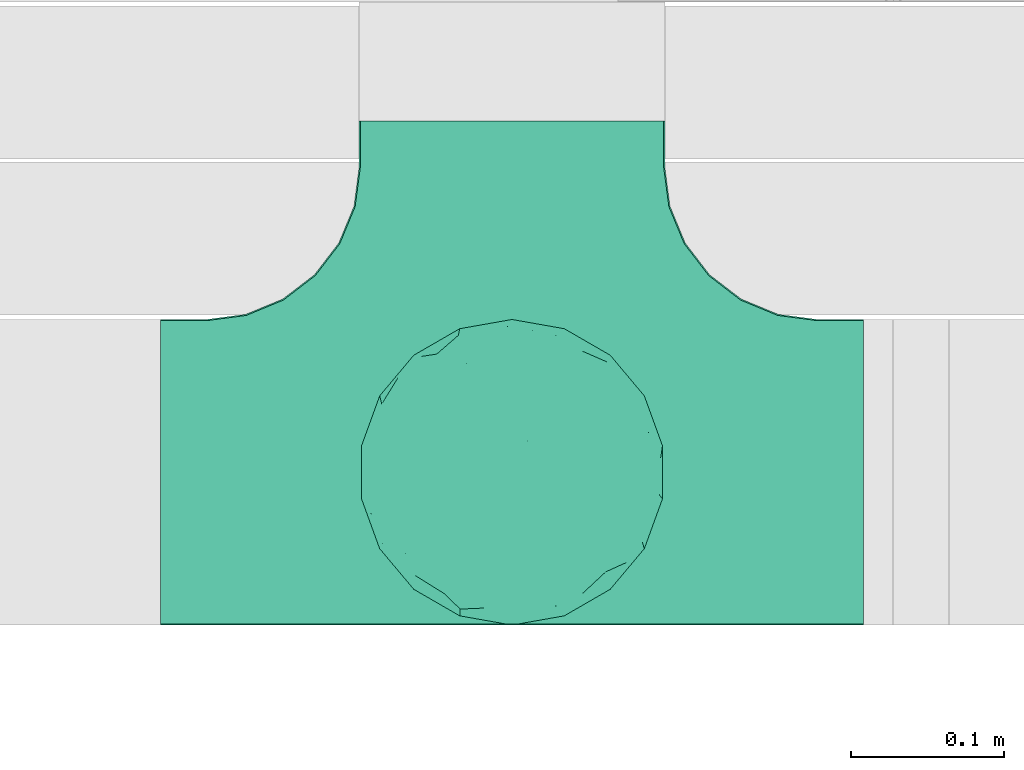
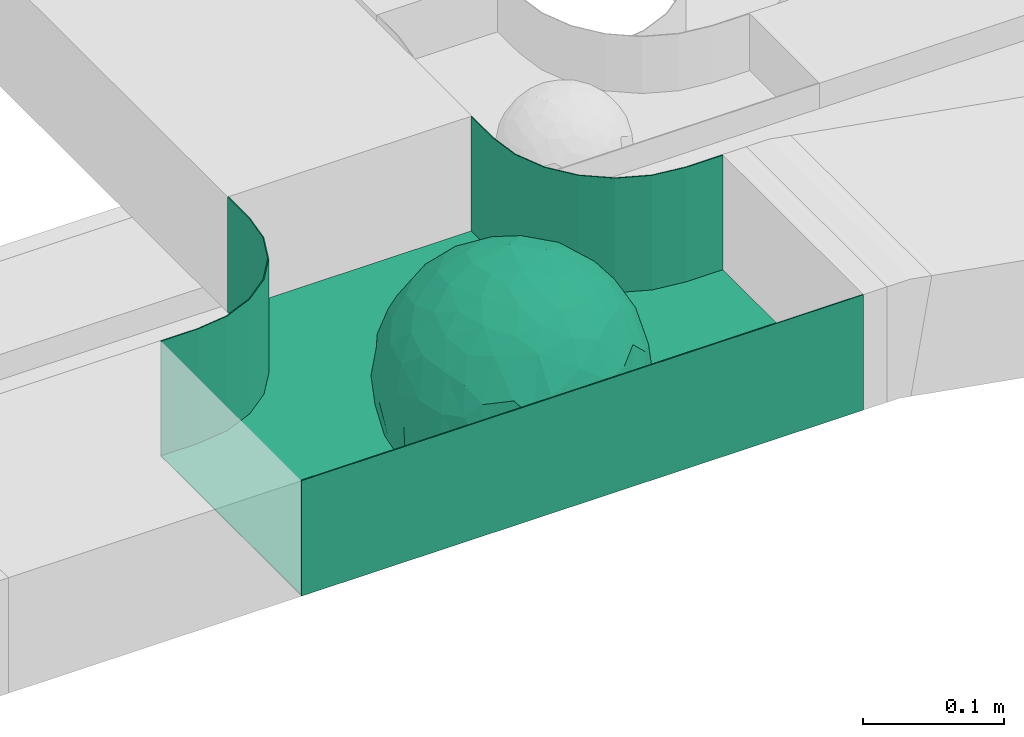
# One storey, part 36 of 38: 1 flow fitting.
"""IFC2X3 building model written with IfcOpenShell, lengths in millimetres."""

from ifc_helpers import new_model, entity, si_unit, converted_unit, derived_unit, direction, frame, origin, place, context, subcontext, project, spatial, faceted_brep, source, transform, mapped, material, material_list, type_object, type_shapes, element, save


model = new_model("IFC2X3")

# Units and contexts
model_context = context("Model", 3, precision=0.01, world=origin(), true_north=direction((6.12303176911189e-17, 1.0)))
body_context = subcontext(model_context, "Body", "Model", "MODEL_VIEW")
ifc_project = project(units=[si_unit("LENGTHUNIT", "METRE", prefix="MILLI"), si_unit("AREAUNIT", "SQUARE_METRE"), si_unit("VOLUMEUNIT", "CUBIC_METRE"), converted_unit("PLANEANGLEUNIT", "DEGREE", entity("IfcRatioMeasure", 0.0174532925199433), si_unit("PLANEANGLEUNIT", "RADIAN"), dimensions=[0, 0, 0, 0, 0, 0, 0]), si_unit("MASSUNIT", "GRAM", prefix="KILO"), derived_unit("MASSDENSITYUNIT", [(si_unit("MASSUNIT", "GRAM", prefix="KILO"), 1), (si_unit("LENGTHUNIT", "METRE"), -3)]), derived_unit("MOMENTOFINERTIAUNIT", [(si_unit("LENGTHUNIT", "METRE"), 4)]), si_unit("TIMEUNIT", "SECOND"), si_unit("FREQUENCYUNIT", "HERTZ"), si_unit("THERMODYNAMICTEMPERATUREUNIT", "DEGREE_CELSIUS"), derived_unit("THERMALTRANSMITTANCEUNIT", [(si_unit("MASSUNIT", "GRAM", prefix="KILO"), 1), (si_unit("THERMODYNAMICTEMPERATUREUNIT", "KELVIN"), -1), (si_unit("TIMEUNIT", "SECOND"), -3)]), derived_unit("VOLUMETRICFLOWRATEUNIT", [(si_unit("LENGTHUNIT", "METRE"), 3), (si_unit("TIMEUNIT", "SECOND"), -1)]), derived_unit("MASSFLOWRATEUNIT", [(si_unit("MASSUNIT", "GRAM", prefix="KILO"), 1), (si_unit("TIMEUNIT", "SECOND"), -1)]), derived_unit("ROTATIONALFREQUENCYUNIT", [(si_unit("TIMEUNIT", "SECOND"), -1)]), si_unit("ELECTRICCURRENTUNIT", "AMPERE"), si_unit("ELECTRICVOLTAGEUNIT", "VOLT"), si_unit("POWERUNIT", "WATT"), si_unit("FORCEUNIT", "NEWTON", prefix="KILO"), si_unit("ILLUMINANCEUNIT", "LUX"), si_unit("LUMINOUSFLUXUNIT", "LUMEN"), si_unit("LUMINOUSINTENSITYUNIT", "CANDELA"), derived_unit("USERDEFINED", [(si_unit("MASSUNIT", "GRAM", prefix="KILO"), -1), (si_unit("LENGTHUNIT", "METRE"), -2), (si_unit("TIMEUNIT", "SECOND"), 3), (si_unit("LUMINOUSFLUXUNIT", "LUMEN"), 1)]), derived_unit("LINEARVELOCITYUNIT", [(si_unit("LENGTHUNIT", "METRE"), 1), (si_unit("TIMEUNIT", "SECOND"), -1)]), si_unit("PRESSUREUNIT", "PASCAL"), derived_unit("USERDEFINED", [(si_unit("LENGTHUNIT", "METRE"), -2), (si_unit("MASSUNIT", "GRAM", prefix="KILO"), 1), (si_unit("TIMEUNIT", "SECOND"), -2)]), derived_unit("LINEARFORCEUNIT", [(si_unit("MASSUNIT", "GRAM", prefix="KILO"), 1), (si_unit("LENGTHUNIT", "METRE"), 1), (si_unit("TIMEUNIT", "SECOND"), -2), (si_unit("LENGTHUNIT", "METRE"), -1)]), derived_unit("PLANARFORCEUNIT", [(si_unit("MASSUNIT", "GRAM", prefix="KILO"), 1), (si_unit("LENGTHUNIT", "METRE"), 1), (si_unit("TIMEUNIT", "SECOND"), -2), (si_unit("LENGTHUNIT", "METRE"), -2)])], contexts=[model_context])

# Site, building, storey
site_placement = place(None, frame((0.0, -0.00077364408347762, 0.0)))
site = spatial("IfcSite", under=ifc_project, at=site_placement, CompositionType="ELEMENT")
building_placement = place(site_placement, origin())
building = spatial("IfcBuilding", under=site, at=building_placement, CompositionType="ELEMENT")
storey_placement = place(building_placement, frame((0.0, 0.0, 4200.0)))
storey = spatial("IfcBuildingStorey", under=building, at=storey_placement, CompositionType="ELEMENT", Elevation=4200.0)

# Flow fitting
ifc_material_1 = material()
ifc_material_2 = material()
ifc_material_list = material_list([ifc_material_1, ifc_material_2])
cable_carrier_fitting_type = type_object("IfcCableCarrierFittingType", PredefinedType="NOTDEFINED", material=ifc_material_1)
shared_shape = source(origin(), body_context, "Body", "Brep", [
    faceted_brep([(76.4840203203325, -37.7983376575012, -52.1678090968869), (89.2874188526836, -26.168482477916, -36.6465190629256), (85.270060821053, -46.6341564571094, -23.5429857730317), (-17.2892276551183, -34.784102350051, -92.1474298653505), (3.07548730030541e-06, -44.1611501073546, -89.7206376548624), (-24.6383925717335, -51.5777741549417, -82.0529269721827), (76.3287929967882, -15.079107031813, -62.8214604317408), (55.5757044674811, -29.5498647779489, -77.7055118028838), (-17.1010071662778, 96.9846310392869, 0.0), (-18.6742130440203, 88.8859886245005, -41.8396318510259), (-33.8953581705111, 89.5312614551001, -28.9008289976074), (-45.4623263334585, -10.4806178463803, -88.4496101399357), (-19.8193717281607, 5.04030654129894, -97.8866069197874), (-23.6628375063711, -16.1276312747485, -95.8121580521565), (92.5416578398381, 33.6824088833379, 0.0), (85.2767902974019, 45.7715256118899, -25.1562413673598), (86.6025403784496, 50.0, 0.0), (49.240387650616, -85.2868531952529, 0.0), (62.2001900548409, -72.1916708642314, -30.3232421580155), (64.2787609686595, -76.6044443119063, 0.0), (97.1714774391015, -8.71557429474411, -21.948638614181), (90.7615649771405, 0.0, -41.9802134689751), (96.1413151932242, 14.3969945426304, -23.4429959914917), (98.4807753012265, 17.3648177666844, 0.0), (98.4807753012265, 0.0, 0.0), (79.0119763428423, 8.47783312434252, -60.7061276965826), (76.4840203202329, 37.7983376578076, -52.1678090967986), (87.696722672108, 23.4364088603614, -41.9525871943713), (29.163429357778, -37.5977865113054, -87.9539699930814), (20.3014061890807, -63.7692165377112, -74.3057193553274), (-69.6223300212076, 53.192794202726, -48.2001847229044), (-47.2059268691477, 56.745965379315, -67.4647751170325), (-61.603837577254, 43.4748411443104, -65.6879394046569), (29.4497539748763, 71.3200718492295, -63.6094280923684), (47.2059306757939, 56.745965229418, -67.4647725795649), (30.0444734578003, 49.6507498561999, -81.4379067348793), (-49.6683382574198, -77.0947032728586, -39.8680687018642), (-34.202014332561, -93.9692620785994, 0.0), (-49.2403876506046, -85.2868531952529, 0.0), (61.3953921577507, 65.1440685107005, -44.5741647108287), (74.6816445462022, 59.1436972034819, -30.4084700203242), (61.9457748290475, 44.5417169664605, -64.6433015130544), (28.7737714324073, -89.42049207415, -34.2935223442239), (34.2020143325724, -93.9692620785994, 0.0), (25.6515107494307, -95.4769465589517, 0.0), (17.101007166289, -96.9846310393039, 0.0), (-64.2787609686481, -76.6044443119063, 0.0), (-75.4406506735431, -63.3022221559575, 0.0), (-74.7500995498228, -61.5460620722206, -24.9900952517949), (7.49675578587143, -83.6888268592038, -54.2215723823823), (36.4863653716413, -70.367842623822, -60.9681217230515), (-76.4840178500364, -37.798342255337, -52.1678093872333), (-87.0716088907139, -22.4880335791362, -43.7358350889169), (-79.0617266871127, -6.53517927425345, -60.8813173732629), (63.5329768828015, 0.0, -77.2240949989638), (-63.5329752663337, -4.28405924068898e-09, -77.2240963288374), (-81.9271917640341, 16.0413321025015, -55.0509846781547), (-98.4807753012151, -17.3648177667017, 0.0), (-95.569577544237, -17.0482102820805, -23.9961324840668), (-92.5416578398266, -33.6824088833551, 0.0), (65.8639795091221, 23.4057144961932, -71.5129969456177), (-19.2962502251216, 70.2650181304482, -68.487093341555), (-44.3250940555787, 79.4239687498613, -41.5586239543935), (-76.4840178487499, 37.7983422512769, -52.1678093920491), (-45.0467119602772, 37.358552492076, -81.0871894768975), (-67.1951546795767, 22.414876352536, -70.586007860525), (45.8905780821677, 15.5420810523434, -87.478560572553), (-67.1382383390432, -22.457587679949, -70.6265793333204), (-97.6852110527561, 5.09344694659685, -20.7763408659754), (-90.761561927752, 1.63062869873443e-09, -41.9802200617526), (-92.5416578398267, 33.6824088833379, 0.0), (-92.1520232806737, 27.1973992873941, -27.7183346772189), (28.8657365411401, 87.5169428696254, -38.8272322563751), (7.49675578553467, 83.6888268595355, -54.2215723818906), (1.22951801366171, 95.7251008343745, -28.8997120349128), (3.5162183498022, -95.8354910731824, -28.3406926393789), (-8.55050358313599, -98.4923155196562, 0.0), (-12.2828353145794, -96.1465810571431, -24.5960750457924), (75.4406506735547, 63.3022221559403, 0.0), (64.2787609686598, 76.6044443118892, 0.0), (75.4406506735545, -63.3022221559575, 0.0), (86.6025403784495, -50.0, 0.0), (-75.4406506735433, 63.3022221559403, 0.0), (-84.8930621241031, 46.8074333743426, -24.5404193953063), (-86.6025403784383, 50.0, 0.0), (-65.6229030223494, -61.3889655017833, -43.8751582736728), (-47.2059268729136, -56.7459653834318, -67.4647751109489), (-85.2400449211107, -44.6766589600176, -27.1685642980393), (46.0205786918846, 37.1654843094529, -80.6277440643515), (-63.1788213480048, 67.6783588085196, -37.7898965605855), (-7.15444733827542, -67.6177156734158, -73.3257008857939), (31.5424765006817, -5.30265693589207, -94.7467888934671), (9.84735642755859, -20.4964224402077, -97.3803175109847), (1.0083019663368e-06, 13.3030981775211, -99.111187960177), (49.3513473168359, -11.1781440260195, -86.252499176233), (92.541657839838, -33.6824088833551, 0.0), (98.4807753012265, -17.3648177667017, 0.0), (49.2403876506163, 85.2868531952358, 0.0), (46.4041236261553, 79.1080859305986, -39.8568444672194), (34.2020143325727, 93.9692620785823, 0.0), (-53.1130236264114, 15.1205787052499, -83.3689079985849), (64.5322070769988, -54.17210261472, -53.8607236125959), (47.2059306758545, -56.745965228813, -67.4647725800455), (22.8875622085795, 27.5743091168824, -93.3585399032859), (74.6816445462803, -59.1436972033529, -30.4084700204161), (46.4041236262572, -79.108085930386, -39.8568444675565), (-15.7383008676665, 23.1933977335444, -95.9915214348144), (2.80963889519618, 33.9846447662373, -94.0061160211894), (9.20690877800443, 52.3900236205866, -84.6789126984153), (9.72607601259755, 69.7500364970203, -70.995322761851), (17.1010071662892, 96.9846310392869, 0.0), (-5.62154210059744, -90.1648531765776, -42.8800363346189), (0.0, -100.0, 0.0), (-25.1293295965289, -93.3686387308287, -25.5110582999201), (-25.949186528859, -84.8833009001169, -46.0593632912046), (-17.1010071662777, -96.9846310393039, 0.0), (-10.2354907319271, -80.7824512711375, -58.0467940208873), (-31.237630661844, -69.7640997378305, -64.4762035048911), (-42.1850269133029, -33.6354441712551, -84.1966768924114), (-35.781529361024, 18.547890266457, -91.5186206367184), (-61.619736792185, -43.523827571712, -65.6405703141646), (-17.3443611696694, 40.8888850191612, -89.595045719636), (-29.1001411816516, 55.690814260002, -77.7927695243168), (-10.6569193640809, 57.0342754657797, -81.4464332660353), (-59.774866149928, -75.5723898452015, -26.7540514659609), (-86.6025403784381, -50.0, 0.0), (-98.4807753012151, 0.0, 0.0), (-98.4807753012152, 17.3648177666844, 0.0), (-74.7670053246598, 60.7049605869996, -26.9221595513964), (-64.2787609686484, 76.6044443118892, 0.0), (-49.2403876506049, 85.2868531952358, 0.0), (-34.2020143325614, 93.9692620785823, 0.0), (0.0, 100.0, 0.0), (-76.484019526794, -37.798337198235, 52.1678105930665), (-89.2874185112873, -26.1684825046027, 36.6465198756512), (-85.2700607126513, -46.6341564521743, 23.5429861753997), (17.2892307880813, -34.7841011602588, 92.1474297266695), (-3.38734512270379e-07, -44.1611496359296, 89.720637886916), (24.6383956411536, -51.5777728113463, 82.0529268951053), (-76.3287917934888, -15.0791068021182, 62.8214619488982), (-55.5757026100472, -29.549864599369, 77.7055131992549), (18.6742091034424, 88.885990914275, 41.8396287453374), (33.8953586129312, 89.5312597468659, 28.9008337706599), (17.3443607633453, 40.8888810970192, 89.5950475882768), (15.7383028761951, 23.1933956687767, 95.9915216044101), (35.7815318404767, 18.5478901047313, 91.5186197001092), (-85.2767901734143, 45.7715256234335, 25.1562417666364), (-62.2001897574699, -72.1916707653145, 30.3232430034808), (-97.1714773187454, -8.71557427953189, 21.9486391530291), (-96.141315013212, 14.3969947624817, 23.4429965946852), (-79.0119753418501, 8.47783306286876, 60.7061290080075), (-76.4840195267832, 37.7983371982528, 52.1678105930571), (-87.6967222099395, 23.4364087722604, 41.9525882096856), (-29.163427099677, -37.5977868949179, 87.9539705778413), (-20.301404034393, -63.7692173365967, 74.305719258427), (69.6223307049661, 53.192787114506, 48.2001915577083), (47.2059293170501, 56.7459646829409, 67.4647739899622), (61.6038389573326, 43.4748357207471, 65.6879416999347), (-61.3953919237905, 65.1440676388516, 44.5741663072653), (49.2659552585237, -77.3488009806731, 39.8751631886295), (-74.681644350378, 59.1436969740875, 30.4084709474116), (-61.9457736264423, 44.5417164806275, 64.643303000237), (-7.49675472945651, -83.6888265867081, 54.2215729490431), (-36.486364416374, -70.367842442625, 60.968122503872), (-28.7737710558201, -89.4204919730988, 34.2935229236939), (74.7446466999101, -61.6521905333982, 24.7435889098862), (3.00446277704405, -95.5180690083503, 29.4494770130044), (-13.4675721353261, -92.748406770264, 34.876317786707), (76.4840204055964, -37.7983390347103, 52.167807974034), (87.0716107179514, -22.4880293497667, 43.7358336258448), (79.0617298359488, -6.53517466347878, 60.8813137790831), (-63.5329751791014, 0.0, 77.2240964006191), (63.5329772594296, 0.0, 77.2240946891232), (81.9271971902465, 16.0413321407425, 55.050976591722), (95.5695783977716, -17.0482115223089, 23.9961282036192), (-65.8639781491499, 23.405714160557, 71.5129983080176), (19.2962569358552, 70.2650237882598, 68.4870856461333), (44.3251010195622, 79.4239674638786, 41.5586189845396), (76.4840204055789, 37.7983390346199, 52.1678079741129), (45.0467113579588, 37.35855313631, 81.0871895147151), (67.1951616703757, 22.4148716107117, 70.5860027113649), (-45.8905758090763, 15.5420810346383, 87.4785617681537), (67.1382437930653, -22.4575840893256, 70.6265752904385), (97.6852138116852, 5.09344112492882, 20.7763293214556), (90.7615650780775, 0.0, 41.9802132507632), (92.1520274335419, 27.1973943799444, 27.7183256859159), (-28.8657360653296, 87.5169427229152, 38.8272329408042), (-7.49675472951015, 83.6888265867653, 54.2215729489213), (-1.22952463606755, 95.725101063195, 28.8997109952541), (7.15445060231028, -67.6177152767913, 73.3257009330848), (30.0445391888188, -71.0236195697132, 63.6629494144802), (-90.7615645164956, 0.0, 41.9802144648834), (84.8930644946618, 46.8074299509675, 24.5404177244603), (65.657396767693, -61.8519680594647, 43.1675838664051), (47.2059293174508, -56.7459646832734, 67.4647739894163), (85.240045822543, -44.6766582374337, 27.1685626581248), (-30.0444712047215, 49.6507502843406, 81.4379073050796), (-47.2059295896367, 56.7459650911412, 67.4647734558766), (-46.0205764805425, 37.1654842487523, 80.6277453545262), (63.1788267861392, 67.6783521071165, 37.7898994705241), (-31.542473908998, -5.30265693887445, 94.7467897561175), (-9.84735391303847, -20.4964227184575, 97.3803177067078), (1.34873765353802e-06, 13.3030991109957, 99.1111878348972), (-49.3513452292634, -11.1781439777262, 86.2525003769525), (-46.4041232356316, 79.1080858261746, 39.8568451291574), (-29.4497536788485, 71.3200715314942, 63.609428585683), (24.3100719261245, -93.7923353358836, 24.7390023078953), (-64.5322063997089, -54.1721023527289, 53.8607246875848), (-47.2059295895764, -56.7459650910276, 67.4647734560286), (-22.8875602129064, 27.5743087068143, 93.3585405136699), (-46.4041232356225, -79.1080858261415, 39.8568451292672), (-74.6816443503883, -59.1436969740864, 30.408470947421), (19.8193741532226, 5.04030693924503, 97.8866064083047), (-2.80963679644177, 33.9846454726014, 94.0061158285697), (-9.20690598859987, 52.3900245858364, 84.6789124045226), (-9.72607582248976, 69.7500367089908, 70.9953225796557), (9.6507963138497, -80.5368358032807, 58.4865814465705), (23.4705761898964, -86.311306248728, 44.7156624344864), (35.1118074315221, -89.6215726748419, 27.113367370765), (42.1850318693192, -33.6354421467953, 84.1966752180655), (23.6628407100174, -16.1276300406404, 95.8121574686978), (45.4623290073054, -10.4806171517165, 88.4496088479348), (61.6197386049218, -43.5238234805734, 65.6405713251752), (29.1001407425045, 55.6908137196801, 77.7927700754181), (10.6569061579526, 57.0342796833114, 81.4464320406166), (59.3537179746501, -75.8188405832575, 26.9933246414488), (74.7670061544982, 60.7049632941286, 26.9221511427291), (53.1130277137063, 15.1205817594398, 83.3689048407183)], [[[0, 1, 2]], [[3, 4, 5]], [[6, 0, 7]], [[8, 9, 10]], [[11, 12, 13]], [[14, 15, 16]], [[17, 18, 19]], [[20, 21, 22]], [[22, 23, 24]], [[25, 26, 27]], [[4, 28, 29]], [[30, 31, 32]], [[33, 34, 35]], [[36, 37, 38]], [[39, 40, 41]], [[42, 43, 44, 45]], [[46, 47, 48]], [[49, 50, 42]], [[51, 52, 53]], [[54, 25, 6]], [[55, 53, 56]], [[57, 58, 59]], [[26, 25, 60]], [[61, 31, 62]], [[32, 63, 30]], [[64, 65, 32]], [[54, 66, 60]], [[53, 67, 51]], [[58, 68, 69]], [[68, 70, 71]], [[72, 73, 74]], [[75, 76, 77]], [[6, 7, 54]], [[24, 20, 22]], [[78, 40, 79]], [[15, 26, 40]], [[1, 21, 20]], [[80, 2, 81]], [[63, 56, 71]], [[82, 83, 84]], [[36, 85, 86]], [[87, 58, 52]], [[35, 34, 88]], [[62, 31, 89]], [[42, 75, 49]], [[4, 29, 90]], [[91, 92, 93]], [[7, 94, 54]], [[6, 1, 0]], [[95, 81, 2]], [[24, 96, 20]], [[1, 20, 95]], [[1, 95, 2]], [[27, 22, 21]], [[15, 14, 22]], [[25, 27, 21]], [[15, 78, 16]], [[41, 40, 26]], [[40, 78, 15]], [[39, 97, 79]], [[97, 98, 99]], [[40, 39, 79]], [[33, 73, 72]], [[21, 1, 6]], [[25, 54, 60]], [[64, 100, 65]], [[26, 15, 27]], [[6, 25, 21]], [[0, 101, 7]], [[102, 28, 7]], [[92, 91, 28]], [[94, 28, 91]], [[88, 34, 41]], [[54, 94, 66]], [[41, 26, 60]], [[103, 91, 93]], [[88, 41, 60]], [[20, 96, 95]], [[101, 18, 102]], [[104, 80, 19]], [[101, 0, 104]], [[18, 105, 102]], [[43, 42, 105]], [[17, 43, 105]], [[29, 28, 102]], [[28, 4, 92]], [[105, 50, 102]], [[90, 29, 49]], [[88, 60, 66]], [[41, 34, 39]], [[34, 98, 39]], [[97, 39, 98]], [[103, 66, 91]], [[88, 66, 103]], [[12, 106, 93]], [[33, 98, 34]], [[107, 103, 93]], [[35, 103, 108]], [[103, 35, 88]], [[33, 109, 73]], [[109, 35, 108]], [[110, 72, 74]], [[72, 110, 99]], [[98, 33, 72]], [[99, 98, 72]], [[80, 104, 2]], [[0, 2, 104]], [[101, 104, 18]], [[7, 101, 102]], [[19, 18, 104]], [[105, 18, 17]], [[77, 111, 75]], [[75, 45, 112]], [[113, 114, 111]], [[115, 77, 76]], [[36, 114, 37]], [[90, 5, 4]], [[75, 42, 45]], [[50, 49, 29]], [[49, 116, 90]], [[5, 117, 86]], [[90, 116, 117]], [[118, 13, 3]], [[118, 5, 86]], [[11, 119, 12]], [[67, 120, 51]], [[11, 13, 118]], [[65, 55, 56]], [[121, 122, 123]], [[90, 117, 5]], [[51, 120, 85]], [[117, 36, 86]], [[36, 117, 114]], [[46, 48, 124]], [[38, 124, 36]], [[85, 124, 48]], [[87, 125, 59]], [[125, 87, 47]], [[48, 51, 85]], [[68, 57, 126, 127]], [[59, 58, 87]], [[58, 69, 52]], [[53, 52, 69]], [[87, 52, 51]], [[56, 53, 69]], [[53, 55, 67]], [[71, 56, 69]], [[56, 63, 65]], [[71, 69, 68]], [[128, 129, 89]], [[11, 67, 55]], [[120, 118, 86]], [[32, 65, 63]], [[100, 55, 65]], [[118, 120, 67]], [[85, 120, 86]], [[129, 128, 82]], [[64, 32, 31]], [[62, 130, 131]], [[130, 62, 89]], [[9, 73, 61]], [[10, 62, 131]], [[109, 61, 73]], [[73, 9, 74]], [[64, 121, 119]], [[122, 61, 123]], [[64, 119, 100]], [[64, 31, 122]], [[107, 108, 103]], [[47, 87, 48]], [[51, 48, 87]], [[57, 68, 58]], [[64, 122, 121]], [[89, 129, 130]], [[67, 11, 118]], [[11, 55, 100]], [[82, 128, 83]], [[30, 128, 89]], [[83, 63, 71]], [[63, 83, 128]], [[84, 83, 71]], [[10, 61, 62]], [[74, 8, 132]], [[8, 74, 9]], [[110, 74, 132]], [[3, 92, 4]], [[92, 13, 12]], [[22, 27, 15]], [[14, 23, 22]], [[11, 100, 119]], [[128, 30, 63]], [[31, 30, 89]], [[28, 94, 7]], [[66, 94, 91]], [[42, 50, 105]], [[29, 102, 50]], [[106, 107, 93]], [[123, 107, 121]], [[35, 109, 33]], [[109, 108, 123]], [[75, 112, 76]], [[113, 77, 115]], [[114, 116, 111]], [[115, 37, 113]], [[37, 114, 113]], [[49, 75, 111]], [[117, 116, 114]], [[111, 77, 113]], [[49, 111, 116]], [[118, 3, 5]], [[92, 3, 13]], [[106, 119, 121]], [[92, 12, 93]], [[119, 106, 12]], [[107, 106, 121]], [[46, 124, 38]], [[85, 36, 124]], [[70, 68, 127]], [[70, 84, 71]], [[31, 61, 122]], [[109, 123, 61]], [[107, 123, 108]], [[8, 10, 131]], [[61, 10, 9]], [[133, 134, 135]], [[136, 137, 138]], [[139, 133, 140]], [[110, 141, 142]], [[143, 144, 145]], [[70, 146, 84]], [[38, 147, 46]], [[126, 57, 148]], [[149, 127, 126]], [[150, 151, 152]], [[137, 153, 154]], [[155, 156, 157]], [[130, 129, 158]], [[159, 43, 17]], [[158, 160, 161]], [[162, 163, 164]], [[19, 80, 165]], [[166, 167, 115]], [[168, 169, 170]], [[171, 150, 139]], [[172, 170, 173]], [[96, 174, 95]], [[151, 150, 175]], [[176, 156, 177]], [[157, 178, 155]], [[179, 180, 157]], [[171, 181, 175]], [[170, 182, 168]], [[174, 183, 184]], [[185, 23, 14, 16]], [[186, 187, 188]], [[138, 189, 190]], [[139, 140, 171]], [[126, 148, 149]], [[82, 160, 129]], [[146, 151, 160]], [[134, 191, 148]], [[47, 135, 125]], [[178, 173, 185]], [[78, 192, 16]], [[159, 193, 194]], [[195, 174, 169]], [[196, 197, 198]], [[177, 156, 199]], [[166, 112, 45]], [[154, 189, 137]], [[200, 201, 202]], [[140, 203, 171]], [[191, 149, 148]], [[59, 125, 135]], [[133, 139, 134]], [[134, 148, 59]], [[134, 59, 135]], [[152, 149, 191]], [[146, 70, 149]], [[150, 152, 191]], [[146, 82, 84]], [[161, 160, 151]], [[160, 82, 146]], [[204, 131, 130]], [[186, 205, 187]], [[160, 158, 129]], [[197, 196, 205]], [[191, 134, 139]], [[150, 171, 175]], [[45, 206, 166]], [[151, 146, 152]], [[139, 150, 191]], [[133, 207, 140]], [[208, 153, 140]], [[201, 200, 153]], [[203, 153, 200]], [[198, 197, 161]], [[171, 203, 181]], [[161, 151, 175]], [[209, 200, 202]], [[198, 161, 175]], [[148, 57, 59]], [[38, 37, 210]], [[211, 47, 46]], [[207, 133, 211]], [[147, 210, 208]], [[210, 37, 164]], [[208, 207, 147]], [[154, 153, 208]], [[153, 137, 201]], [[210, 163, 208]], [[189, 154, 162]], [[198, 175, 181]], [[161, 197, 158]], [[197, 204, 158]], [[130, 158, 204]], [[209, 181, 200]], [[198, 181, 209]], [[212, 144, 202]], [[205, 204, 197]], [[213, 209, 202]], [[196, 209, 214]], [[209, 196, 198]], [[205, 215, 187]], [[215, 196, 214]], [[8, 186, 188]], [[186, 8, 131]], [[204, 205, 186]], [[131, 204, 186]], [[47, 211, 135]], [[133, 135, 211]], [[207, 211, 147]], [[140, 207, 208]], [[46, 147, 211]], [[210, 147, 38]], [[166, 115, 76, 112]], [[115, 164, 37]], [[163, 162, 154]], [[216, 166, 217]], [[138, 137, 189]], [[162, 216, 189]], [[218, 44, 43]], [[44, 218, 206]], [[189, 216, 190]], [[219, 220, 136]], [[219, 138, 194]], [[221, 145, 212]], [[182, 222, 168]], [[221, 220, 219]], [[180, 172, 173]], [[143, 223, 224]], [[168, 222, 193]], [[194, 138, 190]], [[190, 159, 194]], [[190, 217, 218]], [[19, 165, 225]], [[17, 225, 159]], [[193, 225, 165]], [[195, 81, 95]], [[81, 195, 80]], [[165, 168, 193]], [[183, 96, 24, 23]], [[95, 174, 195]], [[174, 184, 169]], [[170, 169, 184]], [[195, 169, 168]], [[173, 170, 184]], [[170, 172, 182]], [[185, 173, 184]], [[173, 178, 180]], [[185, 184, 183]], [[226, 79, 199]], [[221, 182, 172]], [[222, 219, 194]], [[157, 180, 178]], [[227, 172, 180]], [[219, 222, 182]], [[193, 222, 194]], [[79, 226, 78]], [[179, 157, 156]], [[177, 97, 99]], [[97, 177, 199]], [[141, 187, 176]], [[142, 177, 99]], [[215, 176, 187]], [[187, 141, 188]], [[179, 143, 145]], [[223, 176, 224]], [[179, 145, 227]], [[179, 156, 223]], [[213, 214, 209]], [[96, 183, 174]], [[185, 183, 23]], [[80, 195, 165]], [[168, 165, 195]], [[199, 79, 97]], [[182, 221, 219]], [[221, 172, 227]], [[78, 226, 192]], [[155, 226, 199]], [[192, 178, 185]], [[178, 192, 226]], [[16, 192, 185]], [[142, 176, 177]], [[188, 110, 132]], [[110, 188, 141]], [[8, 188, 132]], [[136, 201, 137]], [[201, 220, 212]], [[149, 152, 146]], [[70, 127, 149]], [[167, 162, 164]], [[179, 227, 180]], [[221, 227, 145]], [[226, 155, 178]], [[156, 155, 199]], [[153, 203, 140]], [[181, 203, 200]], [[164, 163, 210]], [[154, 208, 163]], [[144, 213, 202]], [[224, 213, 143]], [[196, 215, 205]], [[215, 214, 224]], [[166, 216, 162]], [[190, 216, 217]], [[218, 217, 206]], [[43, 159, 218]], [[190, 218, 159]], [[166, 206, 217]], [[44, 206, 45]], [[219, 136, 138]], [[201, 136, 220]], [[201, 212, 202]], [[221, 212, 220]], [[145, 144, 212]], [[213, 144, 143]], [[19, 225, 17]], [[193, 159, 225]], [[179, 223, 143]], [[156, 176, 223]], [[215, 224, 176]], [[213, 224, 214]], [[110, 142, 99]], [[176, 142, 141]], [[115, 167, 164]], [[166, 162, 167]]]),
    faceted_brep([(-103.407417371087, -174.118095489753, 50.0), (-100.0, -200.0, 50.0), (-100.0, -230.0, 50.0), (-99.1999999999932, -230.0, 50.0), (-99.1999999999933, -200.0, 50.0), (-102.634676710055, -173.911040253671, 50.0), (-112.704639298522, -149.600000000004, 50.0), (-128.723636456391, -128.7236364564, 50.0), (-149.599999999996, -112.704639298532, 50.0), (-173.911040253663, -102.634676710066, 50.0), (-200.0, -99.2000000000044, 50.0), (-230.0, -99.2000000000044, 50.0), (-230.0, -100.0, 50.0), (-200.0, -100.0, 50.0), (-174.118095489746, -103.407417371099, 50.0), (-150.0, -113.397459621561, 50.0), (-129.28932188134, -129.28932188135, 50.0), (-113.39745962155, -150.0, 50.0), (230.0, -100.0, 50.0), (230.0, -99.2000000000044, 50.0), (200.0, -99.2000000000097, 50.0), (173.911040253722, -102.634676710071, 50.0), (149.60000000005, -112.704639298537, 50.0), (128.723636456439, -128.723636456403, 50.0), (112.704639298563, -149.600000000006, 50.0), (102.634676710086, -173.911040253673, 50.0), (99.2000000000121, -200.0, 50.0), (99.2000000000069, -230.0, 50.0), (100.0, -230.0, 50.0), (100.0, -200.0, 50.0), (103.407417371119, -174.118095489755, 50.0), (113.397459621593, -150.0, 50.0), (129.289321881391, -129.289321881354, 50.0), (150.0, -113.397459621567, 50.0), (174.118095489805, -103.407417371105, 50.0), (200.0, -100.0, 50.0), (230.0, 99.1999999999954, 50.0), (230.0, 100.0, 50.0), (-230.0, 100.0, 50.0), (-230.0, 99.1999999999954, 50.0), (-230.0, -100.0, -50.0), (-230.0, 100.0, -50.0), (230.0, 100.0, -50.0), (230.0, -100.0, -50.0), (200.0, -100.0, -50.0), (174.118095489805, -103.407417371105, -50.0), (150.0, -113.397459621567, -50.0), (129.289321881391, -129.289321881354, -50.0), (113.397459621593, -150.0, -50.0), (103.407417371119, -174.118095489755, -50.0), (100.0, -200.0, -50.0), (100.0, -230.0, -50.0), (-100.0, -230.0, -50.0), (-100.0, -200.0, -50.0), (-103.407417371087, -174.118095489753, -50.0), (-113.39745962155, -150.0, -50.0), (-129.28932188134, -129.28932188135, -50.0), (-150.0, -113.397459621561, -50.0), (-174.118095489746, -103.407417371099, -50.0), (-200.0, -100.0, -50.0), (-100.0, -200.0, -49.1999999999851), (99.2000000000069, -230.0, -49.1999999999851), (-99.1999999999932, -230.0, -49.1999999999851), (-99.1999999999933, -200.0, -49.1999999999851), (-200.0, -99.2000000000044, -49.1999999999851), (-230.0, -99.2000000000044, -49.1999999999851), (230.0, -99.2000000000044, -49.1999999999851), (200.0, -99.2000000000044, -49.1999999999851), (-230.0, 99.1999999999954, -49.1999999999851), (-200.0, -100.0, -49.1999999999851), (200.0, -100.0, -49.1999999999851), (230.0, 99.1999999999954, -49.1999999999851), (99.2000000000121, -200.0, -49.1999999999851), (100.0, -200.0, -49.1999999999851), (-173.911040253663, -102.634676710066, -49.1999999999851), (-149.599999999996, -112.704639298532, -49.1999999999851), (-128.723636456391, -128.7236364564, -49.1999999999851), (-112.704639298522, -149.600000000004, -49.1999999999851), (-102.634676710055, -173.911040253671, -49.1999999999851), (102.634676710086, -173.911040253674, -49.1999999999851), (112.704639298563, -149.600000000007, -49.1999999999851), (128.723636456439, -128.723636456403, -49.1999999999851), (149.60000000005, -112.704639298537, -49.1999999999851), (173.911040253721, -102.634676710071, -49.1999999999851)], [[[0, 1, 2, 3, 4, 5, 6, 7, 8, 9, 10, 11, 12, 13, 14, 15, 16, 17]], [[18, 19, 20, 21, 22, 23, 24, 25, 26, 27, 28, 29, 30, 31, 32, 33, 34, 35]], [[36, 37, 38, 39]], [[40, 41, 42, 43, 44, 45, 46, 47, 48, 49, 50, 51, 52, 53, 54, 55, 56, 57, 58, 59]], [[2, 1, 60, 53, 52]], [[3, 2, 52, 51, 28, 27, 61, 62]], [[4, 3, 62, 63]], [[11, 10, 64, 65]], [[20, 19, 66, 67]], [[39, 38, 41, 40, 12, 11, 65, 68]], [[13, 12, 40, 59, 69]], [[18, 35, 70, 44, 43]], [[19, 18, 43, 42, 37, 36, 71, 66]], [[27, 26, 72, 61]], [[29, 28, 51, 50, 73]], [[38, 37, 42, 41]], [[36, 39, 68, 71]], [[68, 65, 64, 74, 75, 76, 77, 78, 63, 62, 61, 72, 79, 80, 81, 82, 83, 67, 66, 71]], [[14, 13, 69, 59, 58]], [[15, 14, 58, 57]], [[57, 56, 16, 15]], [[17, 16, 56, 55]], [[0, 17, 55, 54]], [[1, 0, 54, 53, 60]], [[5, 78, 77, 6]], [[6, 77, 76, 7]], [[63, 78, 5, 4]], [[8, 75, 74, 9]], [[9, 74, 64, 10]], [[7, 76, 75, 8]], [[21, 83, 82, 22]], [[22, 82, 81, 23]], [[67, 83, 21, 20]], [[24, 80, 79, 25]], [[25, 79, 72, 26]], [[23, 81, 80, 24]], [[30, 29, 73, 50, 49]], [[31, 30, 49, 48]], [[32, 31, 48, 47]], [[34, 33, 46, 45]], [[34, 45, 44, 70, 35]], [[46, 33, 32, 47]]]),
])
type_shapes(cable_carrier_fitting_type, [shared_shape])
flow_fitting_placement = place(storey_placement, frame((14583.5407015969, 11543.7857236441, 2954.05791329438), z_axis=(0.0, 0.0, 1.0), x_axis=(-1.0, 0.0, 0.0)))
element("IfcFlowFitting", 1, at=flow_fitting_placement, inside=storey, type_object=cable_carrier_fitting_type, material=ifc_material_list, Name="470_DKC_S5_T", context=body_context, shape_type="MappedRepresentation", body=[
    mapped(shared_shape, transform((0.0, 0.0, 0.0), scale=1.0)),
])

save(model, "model.ifc")
